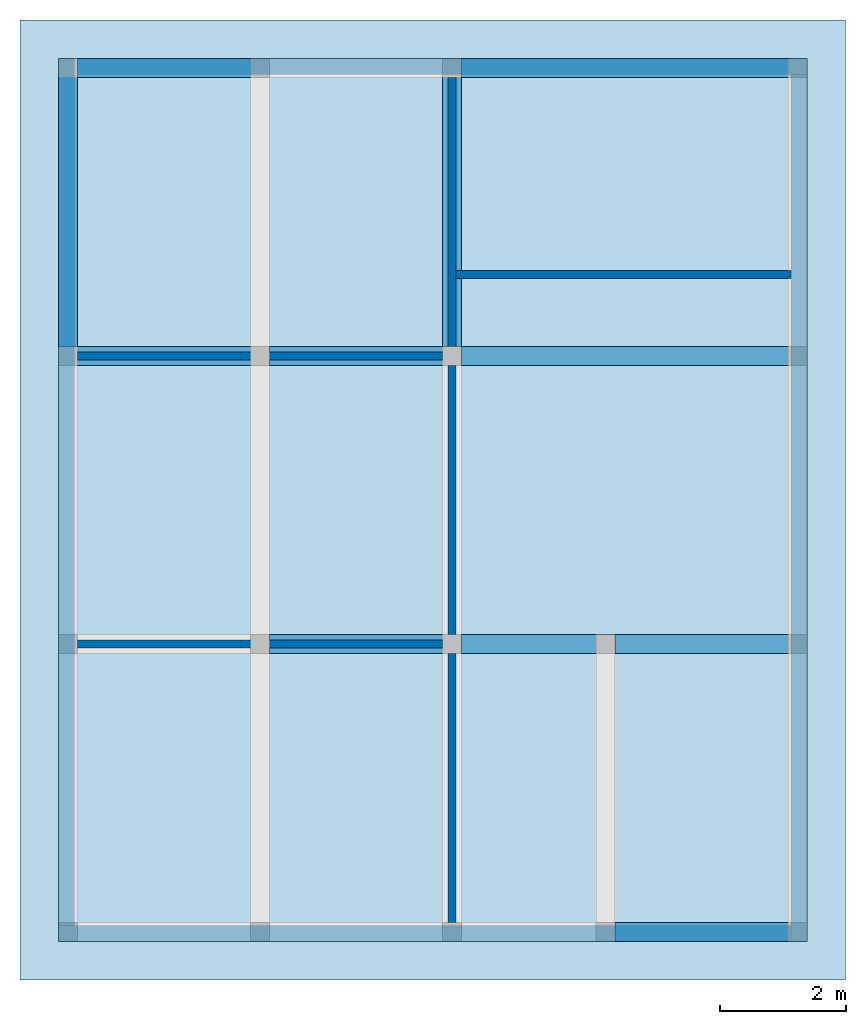
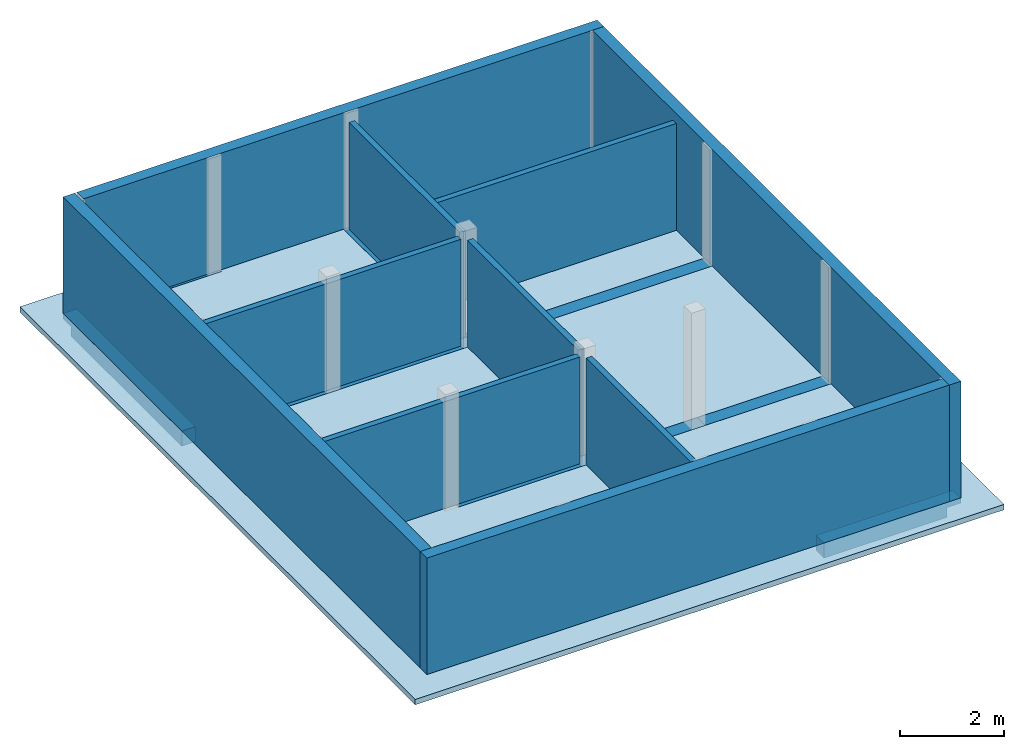
# One storey, part 2 of 2: 11 beams, 10 walls, 1 slab.
"""IFC2X3 building model written with IfcOpenShell, lengths in feet."""

import ifcopenshell
import ifcopenshell.guid

model = None  # the IFC model being written
_history = None  # IfcOwnerHistory: only IFC2X3 demands one
_inside = {}  # id of a spatial element -> (the spatial element, [elements in it])
_under = {}  # id of a project, library or spatial element -> (it, [spatial elements below it])
_declared = {}  # id of a project -> (the project, [libraries it declares])
_typed = {}  # id of a type object -> (the type object, [elements of that type])
_made_of = {}  # id of a material, layer set ... -> (it, [elements and type objects made of it])


def new_model(schema):
    """Start an empty IFC model of exactly this schema.

    Asked for "IFC4X3", IfcOpenShell would pick the latest addendum, in which some entities
    have other attributes; the version numbers below select the first issue.
    IFC2X3 requires an IfcOwnerHistory on every rooted entity: one is made here for all.
    """
    global model, _history
    if schema == "IFC4X3":
        model = ifcopenshell.file(schema_version=(4, 3, 0, 0))
    else:
        model = ifcopenshell.file(schema=schema)
    _inside.clear()
    _under.clear()
    _declared.clear()
    _typed.clear()
    _made_of.clear()
    _history = None
    if model.schema == "IFC2X3":
        org = make("IfcOrganization", Name="unknown")
        user = make(
            "IfcPersonAndOrganization",
            ThePerson=make("IfcPerson", FamilyName="unknown"),
            TheOrganization=org,
        )
        app = make(
            "IfcApplication",
            ApplicationDeveloper=org,
            Version="unknown",
            ApplicationFullName="unknown",
            ApplicationIdentifier="unknown",
        )
        _history = make(
            "IfcOwnerHistory",
            OwningUser=user,
            OwningApplication=app,
            ChangeAction="ADDED",
            CreationDate=0,
        )
    return model


def make(cls, **values):
    """One entity of the class cls with the attributes given. An attribute that is None is left unset."""
    return model.create_entity(
        cls, **{name: value for name, value in values.items() if value is not None}
    )


def entity(cls, *values):
    """Any entity or typed value of the class cls, its attributes in the order of the schema. None: left unset."""
    e = model.create_entity(cls)
    for i, value in enumerate(values):
        if value is not None:
            e[i] = value
    return e


def rooted(cls, **values):
    """An entity with a GlobalId (a new one), such as an element, a storey or a relation."""
    return make(cls, GlobalId=ifcopenshell.guid.new(), OwnerHistory=_history, **values)


def si_unit(unit_type, name, prefix=None):
    """IfcSIUnit, for example si_unit("LENGTHUNIT", "METRE", prefix="MILLI")."""
    return make("IfcSIUnit", UnitType=unit_type, Prefix=prefix, Name=name)


def converted_unit(unit_type, name, factor, base, dimensions=None, offset=None):
    """IfcConversionBasedUnit, such as the inch: factor (a typed value) times the base unit."""
    return make(
        "IfcConversionBasedUnit"
        if offset is None
        else "IfcConversionBasedUnitWithOffset",
        ConversionOffset=offset,
        Dimensions=None
        if dimensions is None
        else entity("IfcDimensionalExponents", *dimensions),
        UnitType=unit_type,
        Name=name,
        ConversionFactor=make(
            "IfcMeasureWithUnit", ValueComponent=factor, UnitComponent=base
        ),
    )


def derived_unit(unit_type, elements):
    """IfcDerivedUnit: a product of units, each with its exponent."""
    return make(
        "IfcDerivedUnit",
        Elements=[
            make("IfcDerivedUnitElement", Unit=unit, Exponent=power)
            for unit, power in elements
        ],
        UnitType=unit_type,
    )


def assignment(units):
    """IfcUnitAssignment: the units of a project."""
    return None if units is None else make("IfcUnitAssignment", Units=units)


def point(xyz):
    """IfcCartesianPoint."""
    return None if xyz is None else make("IfcCartesianPoint", Coordinates=xyz)


def direction(xyz):
    """IfcDirection."""
    return None if xyz is None else make("IfcDirection", DirectionRatios=xyz)


def frame(location, z_axis=None, x_axis=None):
    """IfcAxis2Placement3D, a coordinate frame: its origin and axes. An axis left out is left unset."""
    return make(
        "IfcAxis2Placement3D",
        Location=point(location),
        Axis=direction(z_axis),
        RefDirection=direction(x_axis),
    )


def frame_2d(location, x_axis=None):
    """IfcAxis2Placement2D, a coordinate frame in the plane: its origin and x axis."""
    return make(
        "IfcAxis2Placement2D", Location=point(location), RefDirection=direction(x_axis)
    )


def origin():
    """The frame at (0, 0, 0) with its axes left unset."""
    return frame((0.0, 0.0, 0.0))


def origin_2d_with_axis():
    """The frame at (0, 0) in the plane with the x axis (1, 0) written out."""
    return frame_2d((0.0, 0.0), x_axis=(1.0, 0.0))


def place(relative_to, where):
    """IfcLocalPlacement: puts the frame where relative to a parent placement (None: the world)."""
    return make(
        "IfcLocalPlacement", PlacementRelTo=relative_to, RelativePlacement=where
    )


def context(
    kind, dimensions, precision=None, world=None, true_north=None, identifier=None
):
    """IfcGeometricRepresentationContext, for example the 3D "Model" context."""
    return make(
        "IfcGeometricRepresentationContext",
        ContextIdentifier=identifier,
        ContextType=kind,
        CoordinateSpaceDimension=dimensions,
        Precision=precision,
        WorldCoordinateSystem=world,
        TrueNorth=true_north,
    )


def subcontext(parent, identifier, kind, view, scale=None):
    """IfcGeometricRepresentationSubContext, for example "Body" below "Model"."""
    return make(
        "IfcGeometricRepresentationSubContext",
        ContextIdentifier=identifier,
        ContextType=kind,
        ParentContext=parent,
        TargetScale=scale,
        TargetView=view,
    )


def project(units=None, contexts=None):
    """IfcProject with its units and contexts."""
    return rooted(
        "IfcProject",
        Name="project",
        RepresentationContexts=contexts,
        UnitsInContext=assignment(units),
    )


def spatial(cls, under=None, at=None, **own):
    """A site, building, storey or space (cls), placed at a placement, below another one or the project."""
    s = rooted(cls, ObjectPlacement=at, **own)
    if under is not None:
        _under.setdefault(under.id(), (under, []))[1].append(s)
    return s


def profile(cls, at=None, kind="AREA", **sizes):
    """A parametric profile (cls). Its sizes go by their IFC names, for example OverallWidth=200.0."""
    return make(cls, ProfileType=kind, Position=at, **sizes)


def rectangle(**sizes):
    """IfcRectangleProfileDef."""
    return profile("IfcRectangleProfileDef", **sizes)


def extrude(swept, where, along, depth):
    """IfcExtrudedAreaSolid: the profile swept, set in the frame where, extruded along a direction by depth."""
    return make(
        "IfcExtrudedAreaSolid",
        SweptArea=swept,
        Position=where,
        ExtrudedDirection=direction(along),
        Depth=depth,
    )


def faces_of(points, faces, orient=None, outer=None):
    """IfcFace entities. A face is a list of loops; a loop is a list of indices into points, from 0.

    orient and outer hold one flag for each loop. By default every Orientation is true, the
    first loop of a face is its IfcFaceOuterBound and the others are IfcFaceBound.
    """
    made = []
    for i, loops in enumerate(faces):
        bounds = []
        for j, loop in enumerate(loops):
            is_outer = j == 0 if outer is None else outer[i][j]
            bounds.append(
                make(
                    "IfcFaceOuterBound" if is_outer else "IfcFaceBound",
                    Bound=make("IfcPolyLoop", Polygon=[points[k] for k in loop]),
                    Orientation=True if orient is None else orient[i][j],
                )
            )
        made.append(make("IfcFace", Bounds=bounds))
    return made


def faceted_brep(points, faces, orient=None, outer=None, voids=None):
    """IfcFacetedBrep: a solid bounded by flat faces; with voids (closed shells), ...WithVoids."""
    shared = [point(p) for p in points]
    hull = make("IfcClosedShell", CfsFaces=faces_of(shared, faces, orient, outer))
    if voids is None:
        return make("IfcFacetedBrep", Outer=hull)
    return make(
        "IfcFacetedBrepWithVoids",
        Outer=hull,
        Voids=[
            make(cls, CfsFaces=faces_of(shared, fs, o, b)) for cls, fs, o, b in voids
        ],
    )


def shape(context_of_items, identifier, shape_type, items):
    """IfcShapeRepresentation: the items that make up one representation, for example the "Body"."""
    return make(
        "IfcShapeRepresentation",
        ContextOfItems=context_of_items,
        RepresentationIdentifier=identifier,
        RepresentationType=shape_type,
        Items=items,
    )


def material(Name=None, Category=None):
    """IfcMaterial."""
    return make("IfcMaterial", Name=Name, Category=Category)


def layer(
    of_material, thickness, ventilated=None, Name=None, Category=None, Priority=None
):
    """IfcMaterialLayer: one layer of a wall or slab, of a material (None: an air gap)."""
    return make(
        "IfcMaterialLayer",
        Material=of_material,
        LayerThickness=thickness,
        IsVentilated=ventilated,
        Name=Name,
        Category=Category,
        Priority=Priority,
    )


def layer_set(layers, Name=None):
    """IfcMaterialLayerSet."""
    return make("IfcMaterialLayerSet", MaterialLayers=layers, LayerSetName=Name)


def layer_usage(for_layer_set, set_direction, sense, offset, extent=None):
    """IfcMaterialLayerSetUsage: how a layer set lies in its element."""
    return make(
        "IfcMaterialLayerSetUsage",
        ForLayerSet=for_layer_set,
        LayerSetDirection=set_direction,
        DirectionSense=sense,
        OffsetFromReferenceLine=offset,
        ReferenceExtent=extent,
    )


def made_of(thing, what):
    """Note that an element or type object is made of a material, layer set ...; save() writes the relation."""
    if what is not None:
        _made_of.setdefault(what.id(), (what, []))[1].append(thing)
    return thing


def type_object(cls, material=None, **own):
    """A type object (cls), such as IfcWallType, which elements share."""
    return made_of(rooted(cls, **own), material)


def element(
    cls,
    number,
    at=None,
    inside=None,
    cuts=None,
    type_object=None,
    material=None,
    context=None,
    identifier="Body",
    shape_type=None,
    held_by="IfcProductDefinitionShape",
    body=None,
    shapes=None,
    **own,
):
    """One element of the class cls, such as IfcWall. Its Tag is "e" and its number.

    at: its placement. inside: the storey or other place that contains it. cuts: it is an
    opening in that element (IfcRelVoidsElement). A single representation is given by context,
    identifier, shape_type and body (its items); several are given by shapes. held_by: the class
    of the entity that holds the representations. save() writes the other relations.
    """
    e = rooted(cls, Tag="e%d" % number, ObjectPlacement=at, **own)
    if body is not None:
        shapes = [shape(context, identifier, shape_type, body)]
    if shapes is not None:
        e.Representation = make(held_by, Representations=shapes)
    if inside is not None:
        _inside.setdefault(inside.id(), (inside, []))[1].append(e)
    if cuts is not None:
        rooted(
            "IfcRelVoidsElement", RelatingBuildingElement=cuts, RelatedOpeningElement=e
        )
    if type_object is not None:
        _typed.setdefault(type_object.id(), (type_object, []))[1].append(e)
    return made_of(e, material)


def aggregate(whole, parts):
    """IfcRelAggregates: a whole, such as a stair, and the parts it consists of."""
    return rooted("IfcRelAggregates", RelatingObject=whole, RelatedObjects=parts)


def save(model, path):
    """Write the relations noted so far, then the file.

    IfcRelAggregates (storeys below a building ...), IfcRelContainedInSpatialStructure (elements
    in a storey), IfcRelDefinesByType, IfcRelAssociatesMaterial and IfcRelDeclares: one each for
    every whole, place, type object, material and project.
    """
    for whole, parts in _under.values():
        aggregate(whole, parts)
    for where, things in _inside.values():
        rooted(
            "IfcRelContainedInSpatialStructure",
            RelatedElements=things,
            RelatingStructure=where,
        )
    for kind, things in _typed.values():
        rooted("IfcRelDefinesByType", RelatedObjects=things, RelatingType=kind)
    for what, things in _made_of.values():
        rooted("IfcRelAssociatesMaterial", RelatedObjects=things, RelatingMaterial=what)
    for by, libraries in _declared.values():
        rooted("IfcRelDeclares", RelatingContext=by, RelatedDefinitions=libraries)
    model.write(path)


model = new_model("IFC2X3")

# Units and contexts
model_context = context("Model", 3, precision=0.0001, world=origin(), true_north=direction((6.123031769111886e-17, 1.0)))
body_context = subcontext(model_context, "Body", "Model", "MODEL_VIEW")
ifc_project = project(units=[converted_unit("LENGTHUNIT", "FOOT", entity("IfcLengthMeasure", 0.3048), si_unit("LENGTHUNIT", "METRE"), dimensions=[1, 0, 0, 0, 0, 0, 0]), converted_unit("AREAUNIT", "SQUARE FOOT", entity("IfcAreaMeasure", 0.09290304), si_unit("AREAUNIT", "SQUARE_METRE"), dimensions=[2, 0, 0, 0, 0, 0, 0]), converted_unit("VOLUMEUNIT", "CUBIC FOOT", entity("IfcVolumeMeasure", 0.028316846592000004), si_unit("VOLUMEUNIT", "CUBIC_METRE"), dimensions=[3, 0, 0, 0, 0, 0, 0]), converted_unit("PLANEANGLEUNIT", "DEGREE", entity("IfcPlaneAngleMeasure", 0.017453292519943278), si_unit("PLANEANGLEUNIT", "RADIAN"), dimensions=[0, 0, 0, 0, 0, 0, 0]), si_unit("MASSUNIT", "GRAM", prefix="KILO"), derived_unit("MASSDENSITYUNIT", [(si_unit("MASSUNIT", "GRAM", prefix="KILO"), 1), (si_unit("LENGTHUNIT", "METRE"), -3)]), derived_unit("IONCONCENTRATIONUNIT", [(si_unit("MASSUNIT", "GRAM", prefix="KILO"), 1), (si_unit("LENGTHUNIT", "METRE"), -3)]), derived_unit("MOMENTOFINERTIAUNIT", [(si_unit("LENGTHUNIT", "METRE"), 4)]), si_unit("TIMEUNIT", "SECOND"), si_unit("FREQUENCYUNIT", "HERTZ"), si_unit("THERMODYNAMICTEMPERATUREUNIT", "DEGREE_CELSIUS"), derived_unit("THERMALTRANSMITTANCEUNIT", [(si_unit("MASSUNIT", "GRAM", prefix="KILO"), 1), (si_unit("THERMODYNAMICTEMPERATUREUNIT", "KELVIN"), -1), (si_unit("TIMEUNIT", "SECOND"), -3)]), derived_unit("THERMALCONDUCTANCEUNIT", [(si_unit("MASSUNIT", "GRAM", prefix="KILO"), 1), (si_unit("THERMODYNAMICTEMPERATUREUNIT", "KELVIN"), -1), (si_unit("TIMEUNIT", "SECOND"), -3), (si_unit("LENGTHUNIT", "METRE"), 1)]), derived_unit("VOLUMETRICFLOWRATEUNIT", [(si_unit("LENGTHUNIT", "METRE"), 3), (si_unit("TIMEUNIT", "SECOND"), -1)]), derived_unit("MASSFLOWRATEUNIT", [(si_unit("MASSUNIT", "GRAM", prefix="KILO"), 1), (si_unit("TIMEUNIT", "SECOND"), -1)]), derived_unit("ROTATIONALFREQUENCYUNIT", [(si_unit("TIMEUNIT", "SECOND"), -1)]), si_unit("ELECTRICCURRENTUNIT", "AMPERE"), si_unit("ELECTRICVOLTAGEUNIT", "VOLT"), si_unit("POWERUNIT", "WATT"), converted_unit("FORCEUNIT", "KIP", entity("IfcForceMeasure", 2.088543423315013e-05), si_unit("FORCEUNIT", "NEWTON"), dimensions=[1, 1, -2, 0, 0, 0, 0]), si_unit("ILLUMINANCEUNIT", "LUX"), si_unit("LUMINOUSFLUXUNIT", "LUMEN"), si_unit("LUMINOUSINTENSITYUNIT", "CANDELA"), si_unit("ENERGYUNIT", "JOULE"), derived_unit("USERDEFINED", [(si_unit("MASSUNIT", "GRAM", prefix="KILO"), -1), (si_unit("LENGTHUNIT", "METRE"), -2), (si_unit("TIMEUNIT", "SECOND"), 3), (si_unit("LUMINOUSFLUXUNIT", "LUMEN"), 1)]), derived_unit("USERDEFINED", [(si_unit("MASSUNIT", "GRAM", prefix="KILO"), 1), (si_unit("TIMEUNIT", "SECOND"), -3), (si_unit("LENGTHUNIT", "METRE"), 3), (si_unit("ELECTRICCURRENTUNIT", "AMPERE"), -2)]), derived_unit("SOUNDPOWERUNIT", [(si_unit("MASSUNIT", "GRAM", prefix="KILO"), 1), (si_unit("TIMEUNIT", "SECOND"), -3), (si_unit("LENGTHUNIT", "METRE"), 2)]), derived_unit("SOUNDPRESSUREUNIT", [(si_unit("MASSUNIT", "GRAM", prefix="KILO"), 1), (si_unit("LENGTHUNIT", "METRE"), -1), (si_unit("TIMEUNIT", "SECOND"), -2)]), derived_unit("LINEARVELOCITYUNIT", [(si_unit("LENGTHUNIT", "METRE"), 1), (si_unit("TIMEUNIT", "SECOND"), -1)]), si_unit("PRESSUREUNIT", "PASCAL"), derived_unit("USERDEFINED", [(si_unit("MASSUNIT", "GRAM", prefix="KILO"), 1), (si_unit("LENGTHUNIT", "METRE"), -2), (si_unit("TIMEUNIT", "SECOND"), -2)]), derived_unit("LINEARFORCEUNIT", [(si_unit("MASSUNIT", "GRAM", prefix="KILO"), 1), (si_unit("TIMEUNIT", "SECOND"), -2)]), derived_unit("PLANARFORCEUNIT", [(si_unit("MASSUNIT", "GRAM", prefix="KILO"), 1), (si_unit("LENGTHUNIT", "METRE"), -1), (si_unit("TIMEUNIT", "SECOND"), -2)]), derived_unit("SPECIFICHEATCAPACITYUNIT", [(si_unit("THERMODYNAMICTEMPERATUREUNIT", "KELVIN"), -1), (si_unit("LENGTHUNIT", "METRE"), 2), (si_unit("TIMEUNIT", "SECOND"), -2)]), derived_unit("HEATFLUXDENSITYUNIT", [(si_unit("MASSUNIT", "GRAM", prefix="KILO"), 1), (si_unit("TIMEUNIT", "SECOND"), -3)]), derived_unit("HEATINGVALUEUNIT", [(si_unit("LENGTHUNIT", "METRE"), 2), (si_unit("TIMEUNIT", "SECOND"), -2)]), derived_unit("VAPORPERMEABILITYUNIT", [(si_unit("LENGTHUNIT", "METRE"), -1), (si_unit("TIMEUNIT", "SECOND"), 1)]), derived_unit("DYNAMICVISCOSITYUNIT", [(si_unit("MASSUNIT", "GRAM", prefix="KILO"), 1), (si_unit("TIMEUNIT", "SECOND"), -1), (si_unit("LENGTHUNIT", "METRE"), -1)]), derived_unit("THERMALEXPANSIONCOEFFICIENTUNIT", [(si_unit("THERMODYNAMICTEMPERATUREUNIT", "KELVIN"), -1)]), derived_unit("MODULUSOFELASTICITYUNIT", [(si_unit("MASSUNIT", "GRAM", prefix="KILO"), 1), (si_unit("LENGTHUNIT", "METRE"), -1), (si_unit("TIMEUNIT", "SECOND"), -2)]), derived_unit("ISOTHERMALMOISTURECAPACITYUNIT", [(si_unit("LENGTHUNIT", "METRE"), 3), (si_unit("MASSUNIT", "GRAM", prefix="KILO"), -1)]), derived_unit("MOISTUREDIFFUSIVITYUNIT", [(si_unit("TIMEUNIT", "SECOND"), -1), (si_unit("LENGTHUNIT", "METRE"), 2)]), derived_unit("MASSPERLENGTHUNIT", [(si_unit("MASSUNIT", "GRAM", prefix="KILO"), 1), (si_unit("LENGTHUNIT", "METRE"), -1)]), derived_unit("THERMALRESISTANCEUNIT", [(si_unit("MASSUNIT", "GRAM", prefix="KILO"), -1), (si_unit("TIMEUNIT", "SECOND"), 3), (si_unit("THERMODYNAMICTEMPERATUREUNIT", "KELVIN"), 1)]), derived_unit("ACCELERATIONUNIT", [(si_unit("LENGTHUNIT", "METRE"), 1), (si_unit("TIMEUNIT", "SECOND"), -2)]), derived_unit("ANGULARVELOCITYUNIT", [(si_unit("TIMEUNIT", "SECOND"), -1), (si_unit("PLANEANGLEUNIT", "RADIAN"), 1)]), derived_unit("LINEARSTIFFNESSUNIT", [(si_unit("MASSUNIT", "GRAM", prefix="KILO"), 1), (si_unit("TIMEUNIT", "SECOND"), -2)]), derived_unit("WARPINGCONSTANTUNIT", [(si_unit("LENGTHUNIT", "METRE"), 6)]), derived_unit("LINEARMOMENTUNIT", [(si_unit("MASSUNIT", "GRAM", prefix="KILO"), 1), (si_unit("LENGTHUNIT", "METRE"), 1), (si_unit("TIMEUNIT", "SECOND"), -2)]), derived_unit("TORQUEUNIT", [(si_unit("MASSUNIT", "GRAM", prefix="KILO"), 1), (si_unit("LENGTHUNIT", "METRE"), 2), (si_unit("TIMEUNIT", "SECOND"), -2)])], contexts=[model_context])

# Site, building, storey
site_placement = place(None, origin())
site = spatial("IfcSite", under=ifc_project, at=site_placement, CompositionType="ELEMENT")
building_placement = place(site_placement, origin())
building = spatial("IfcBuilding", under=site, at=building_placement, CompositionType="ELEMENT")
storey_placement = place(building_placement, frame((0.0, 0.0, 9.416666666668288)))
storey = spatial("IfcBuildingStorey", under=building, at=storey_placement, Name="First Floor", CompositionType="ELEMENT", Elevation=9.416666666668288)

# Beams
ifc_material_1 = material(Name="Concrete, Cast-in-Place gray")
beam_type = type_object("IfcBeamType", PredefinedType="NOTDEFINED")
for number, where in (
    (1, (38.37447801916311, -50.34124484724908, -1.1666666666666714)),
    (2, (20.374478019163327, -35.34124484724902, -1.1666666666666714)),
):
    element("IfcBeam", number, at=place(storey_placement, frame(where)), inside=storey, type_object=beam_type, material=ifc_material_1, context=body_context, shape_type="Brep", body=[
        faceted_brep([(10.0, 0.0, 1.1666666666666643), (10.0, 1.0, 1.1666666666666643), (9.0, 1.0, 1.1666666666666643), (0.0, 1.0, 1.1666666666666643), (0.0, 0.0, 1.1666666666666643), (9.0, 0.0, 1.1666666666666643), (0.0, 0.0, 0.7499999999983835), (0.0, 0.0, 0.0), (9.0, 0.0, 0.0), (9.0, 0.0, 0.7499999999983835), (10.0, 0.0, 0.7499999999983835), (0.0, 1.0, 0.0), (9.0, 1.0, 0.0), (10.0, 1.0, 0.7499999999983835), (9.0, 1.0, 0.7499999999983835), (0.0, 1.0, 0.7499999999983835)], [[[0, 1, 2, 3, 4, 5]], [[0, 5, 4, 6, 7, 8, 9, 10]], [[7, 11, 12, 8]], [[3, 2, 1, 13, 14, 12, 11, 15]], [[1, 0, 10, 13]], [[4, 3, 15, 11, 7, 6]], [[14, 9, 8, 12]], [[9, 14, 13, 10]]]),
    ])
beam_1_placement = place(storey_placement, frame((30.37447801916315, -35.34124484724903, -1.1666666666666732)))
element("IfcBeam", 3, at=beam_1_placement, inside=storey, type_object=beam_type, material=ifc_material_1, context=body_context, shape_type="Brep", body=[
    faceted_brep([(8.0, 0.0, 1.166666666666666), (8.0, 1.0, 1.166666666666666), (7.0, 1.0, 1.166666666666666), (0.0, 1.0, 1.166666666666666), (0.0, 0.0, 1.1666666666666679), (7.0, 0.0, 1.1666666666666679), (0.0, 0.0, 0.7499999999983853), (0.0, 0.0, 0.0), (7.0, 0.0, 0.0), (7.0, 0.0, 0.7499999999983853), (8.0, 0.0, 0.7499999999983853), (0.0, 1.0, 0.0), (7.0, 1.0, 0.0), (8.0, 1.0, 0.7499999999983853), (7.0, 1.0, 0.7499999999983853), (0.0, 1.0, 0.7499999999983853)], [[[0, 1, 2, 3, 4, 5]], [[0, 5, 4, 6, 7, 8, 9, 10]], [[7, 11, 12, 8]], [[3, 2, 1, 13, 14, 12, 11, 15]], [[1, 0, 10, 13]], [[4, 3, 15, 11, 7, 6]], [[14, 9, 8, 12]], [[9, 14, 13, 10]]]),
])
beam_2_placement = place(storey_placement, frame((38.37447801916313, -35.34124484724908, -1.1666666666666714)))
element("IfcBeam", 4, at=beam_2_placement, inside=storey, type_object=beam_type, material=ifc_material_1, context=body_context, shape_type="Brep", body=[
    faceted_brep([(10.0, 0.0, 1.1666666666666643), (10.0, 1.0, 1.1666666666666643), (9.0, 1.0, 1.1666666666666643), (0.0, 1.0, 1.1666666666666643), (0.0, 0.0, 1.1666666666666643), (9.0, 0.0, 1.1666666666666643), (0.0, 0.0, 0.7499999999983835), (0.0, 0.0, 0.0), (9.0, 0.0, 0.0), (9.0, 0.0, 0.7499999999983835), (10.0, 0.0, 0.7499999999983835), (0.0, 1.0, 0.0), (9.0, 1.0, 0.0), (10.0, 1.0, 0.7499999999983835), (9.0, 1.0, 0.7499999999983835), (0.0, 1.0, 0.7499999999983835)], [[[0, 1, 2, 3, 4, 5]], [[0, 5, 4, 6, 7, 8, 9, 10]], [[7, 11, 12, 8]], [[3, 2, 1, 13, 14, 12, 11, 15]], [[1, 0, 10, 13]], [[4, 3, 15, 11, 7, 6]], [[14, 9, 8, 12]], [[9, 14, 13, 10]]]),
])
beam_3_placement = place(storey_placement, frame((9.374478019163147, -20.341244847248984, -1.1666666666666714)))
element("IfcBeam", 5, at=beam_3_placement, inside=storey, type_object=beam_type, material=ifc_material_1, context=body_context, shape_type="Brep", body=[
    faceted_brep([(11.0, 0.0, 1.1666666666666643), (11.0, 1.0, 1.1666666666666643), (10.0, 1.0, 1.1666666666666643), (1.0, 1.0, 1.1666666666666643), (0.0, 1.0, 1.1666666666666643), (0.0, 0.0, 1.1666666666666643), (1.0, 0.0, 1.1666666666666643), (10.0, 0.0, 1.1666666666666643), (0.0, 0.0, 0.7499999999983835), (1.0, 0.0, 0.7499999999983835), (1.0, 0.0, 0.0), (10.0, 0.0, 0.0), (10.0, 0.0, 0.7499999999983835), (11.0, 0.0, 0.7499999999983835), (1.0, 1.0, 0.0), (10.0, 1.0, 0.0), (11.0, 1.0, 0.7499999999983835), (10.0, 1.0, 0.7499999999983835), (1.0, 1.0, 0.7499999999983835), (0.0, 1.0, 0.7499999999983835)], [[[0, 1, 2, 3, 4, 5, 6, 7]], [[0, 7, 6, 5, 8, 9, 10, 11, 12, 13]], [[10, 14, 15, 11]], [[4, 3, 2, 1, 16, 17, 15, 14, 18, 19]], [[1, 0, 13, 16]], [[5, 4, 19, 8]], [[9, 18, 14, 10]], [[18, 9, 8, 19]], [[17, 12, 11, 15]], [[12, 17, 16, 13]]]),
])
beam_4_placement = place(storey_placement, frame((20.374478019163355, -20.341244847249012, -1.1666666666666714)))
element("IfcBeam", 6, at=beam_4_placement, inside=storey, type_object=beam_type, material=ifc_material_1, context=body_context, shape_type="Brep", body=[
    faceted_brep([(10.0, 0.0, 1.1666666666666643), (10.0, 1.0, 1.1666666666666643), (9.0, 1.0, 1.1666666666666643), (0.0, 1.0, 1.1666666666666643), (0.0, 0.0, 1.1666666666666643), (9.0, 0.0, 1.1666666666666643), (0.0, 0.0, 0.7499999999983835), (0.0, 0.0, 0.0), (9.0, 0.0, 0.0), (9.0, 0.0, 0.7499999999983835), (10.0, 0.0, 0.7499999999983835), (0.0, 1.0, 0.0), (9.0, 1.0, 0.0), (10.0, 1.0, 0.7499999999983835), (9.0, 1.0, 0.7499999999983835), (0.0, 1.0, 0.7499999999983835)], [[[0, 1, 2, 3, 4, 5]], [[0, 5, 4, 6, 7, 8, 9, 10]], [[7, 11, 12, 8]], [[3, 2, 1, 13, 14, 12, 11, 15]], [[1, 0, 10, 13]], [[4, 3, 15, 11, 7, 6]], [[14, 9, 8, 12]], [[9, 14, 13, 10]]]),
])
beam_5_placement = place(storey_placement, frame((30.374478019163178, -20.341244847249072, -1.1666666666666732)))
element("IfcBeam", 7, at=beam_5_placement, inside=storey, type_object=beam_type, material=ifc_material_1, context=body_context, shape_type="Brep", body=[
    faceted_brep([(18.0, 0.0, 1.166666666666666), (18.0, 1.0, 1.166666666666666), (17.0, 1.0, 1.166666666666666), (0.0, 1.0, 1.166666666666666), (0.0, 0.0, 1.1666666666666679), (17.0, 0.0, 1.1666666666666679), (0.0, 0.0, 0.7499999999983853), (0.0, 0.0, 0.0), (17.0, 0.0, 0.0), (17.0, 0.0, 0.7499999999983853), (18.0, 0.0, 0.7499999999983853), (0.0, 1.0, 0.0), (17.0, 1.0, 0.0), (18.0, 1.0, 0.7499999999983853), (17.0, 1.0, 0.7499999999983853), (0.0, 1.0, 0.7499999999983853)], [[[0, 1, 2, 3, 4, 5]], [[0, 5, 4, 6, 7, 8, 9, 10]], [[7, 11, 12, 8]], [[3, 2, 1, 13, 14, 12, 11, 15]], [[1, 0, 10, 13]], [[4, 3, 15, 11, 7, 6]], [[14, 9, 8, 12]], [[9, 14, 13, 10]]]),
])
for number, where, z_axis, x_axis in (
    (8, (9.374478019162256, -19.34124484724894, -1.1666666666666732), (0.0, 0.0, 1.0), (0.0, -1.0, 0.0)),
    (9, (29.374478019162254, -19.341244847249, -1.1666666666666732), (0.0, 0.0, 1.0), (0.0, -1.0, 0.0)),
):
    element("IfcBeam", number, at=place(storey_placement, frame(where, z_axis=z_axis, x_axis=x_axis)), inside=storey, type_object=beam_type, material=ifc_material_1, context=body_context, shape_type="Brep", body=[
        faceted_brep([(-15.0, 1.0, 1.166666666666666), (-15.0, 0.0, 1.1666666666666679), (-14.0, 0.0, 1.1666666666666679), (0.0, 0.0, 1.166666666666666), (0.0, 1.0, 1.166666666666666), (-14.0, 1.0, 1.166666666666666), (-15.0, 0.0, 0.7499999999983853), (-14.0, 0.0, 0.7499999999983853), (-14.0, 0.0, 0.0), (0.0, 0.0, 0.0), (0.0, 0.0, 0.7499999999983853), (0.0, 1.0, 0.0), (-14.0, 1.0, 0.0), (0.0, 1.0, 0.7499999999983853), (-14.0, 1.0, 0.7499999999983853), (-15.0, 1.0, 0.7499999999983853)], [[[0, 1, 2, 3, 4, 5]], [[3, 2, 1, 6, 7, 8, 9, 10]], [[11, 9, 8, 12]], [[0, 5, 4, 13, 11, 12, 14, 15]], [[1, 0, 15, 6]], [[4, 3, 10, 9, 11, 13]], [[7, 14, 12, 8]], [[14, 7, 6, 15]]]),
    ])
beam_6_placement = place(storey_placement, frame((10.374478019163183, -5.341244847248929, -1.1666666666666714)))
element("IfcBeam", 10, at=beam_6_placement, inside=storey, type_object=beam_type, material=ifc_material_1, context=body_context, shape_type="Brep", body=[
    faceted_brep([(10.0, 0.0, 1.1666666666666643), (10.0, 1.0, 1.1666666666666643), (9.0, 1.0, 1.1666666666666643), (0.0, 1.0, 1.1666666666666643), (0.0, 0.0, 1.1666666666666643), (9.0, 0.0, 1.1666666666666643), (0.0, 0.0, 0.7499999999983835), (0.0, 0.0, 0.0), (9.0, 0.0, 0.0), (9.0, 0.0, 0.7499999999983835), (10.0, 0.0, 0.7499999999983835), (0.0, 1.0, 0.0), (9.0, 1.0, 0.0), (10.0, 1.0, 0.7499999999983835), (9.0, 1.0, 0.7499999999983835), (0.0, 1.0, 0.7499999999983835)], [[[0, 1, 2, 3, 4, 5]], [[0, 5, 4, 6, 7, 8, 9, 10]], [[7, 11, 12, 8]], [[3, 2, 1, 13, 14, 12, 11, 15]], [[1, 0, 10, 13]], [[4, 3, 15, 11, 7, 6]], [[14, 9, 8, 12]], [[9, 14, 13, 10]]]),
])
beam_7_placement = place(storey_placement, frame((30.374478019163202, -5.341244847249021, -1.1666666666666732)))
element("IfcBeam", 11, at=beam_7_placement, inside=storey, type_object=beam_type, material=ifc_material_1, context=body_context, shape_type="Brep", body=[
    faceted_brep([(18.0, 0.0, 1.166666666666666), (18.0, 1.0, 1.166666666666666), (17.0, 1.0, 1.166666666666666), (0.0, 1.0, 1.166666666666666), (0.0, 0.0, 1.1666666666666679), (17.0, 0.0, 1.1666666666666679), (0.0, 0.0, 0.7499999999983853), (0.0, 0.0, 0.0), (17.0, 0.0, 0.0), (17.0, 0.0, 0.7499999999983853), (18.0, 0.0, 0.7499999999983853), (0.0, 1.0, 0.0), (17.0, 1.0, 0.0), (18.0, 1.0, 0.7499999999983853), (17.0, 1.0, 0.7499999999983853), (0.0, 1.0, 0.7499999999983853)], [[[0, 1, 2, 3, 4, 5]], [[0, 5, 4, 6, 7, 8, 9, 10]], [[7, 11, 12, 8]], [[3, 2, 1, 13, 14, 12, 11, 15]], [[1, 0, 10, 13]], [[4, 3, 15, 11, 7, 6]], [[14, 9, 8, 12]], [[9, 14, 13, 10]]]),
])

# Slab
ifc_material_2 = material(Name="Default Floor")
ifc_layer_1 = layer(ifc_material_2, 0.4166666666666667)
ifc_layer_set_1 = layer_set([ifc_layer_1])
ifc_layer_usage_1 = layer_usage(ifc_layer_set_1, "AXIS3", "POSITIVE", 0.0)
slab_type = type_object("IfcSlabType", PredefinedType="FLOOR", material=ifc_layer_set_1)
slab_placement = place(storey_placement, origin())
element("IfcSlab", 12, at=slab_placement, inside=storey, type_object=slab_type, material=ifc_layer_usage_1, PredefinedType="FLOOR", context=body_context, shape_type="SweptSolid", body=[
    extrude(rectangle(XDim=50.00000000000018, YDim=42.99999999999993, at=origin_2d_with_axis()), frame((28.874478019162204, -27.34124484724897, 0.0), z_axis=(0.0, 0.0, -1.0), x_axis=(0.0, 1.0, 0.0)), (0.0, 0.0, 1.0), 0.4166666666666661),
])

# Walls
ifc_material_3 = material(Name="Default Wall")
ifc_layer_2 = layer(ifc_material_3, 0.041666666666666664)
ifc_layer_3 = layer(ifc_material_3, 0.75)
ifc_layer_4 = layer(ifc_material_3, 0.041666666666666664)
ifc_layer_set_2 = layer_set([ifc_layer_2, ifc_layer_3, ifc_layer_4])
ifc_layer_usage_2 = layer_usage(ifc_layer_set_2, "AXIS2", "NEGATIVE", 0.4166666666666667)
wall_type_1 = type_object("IfcWallType", PredefinedType="STANDARD", material=ifc_layer_set_2)
wall_1_placement = place(storey_placement, frame((10.37447801916223, -4.757911513915553, 0.0)))
element("IfcWallStandardCase", 13, at=wall_1_placement, inside=storey, type_object=wall_type_1, material=ifc_layer_usage_2, context=body_context, shape_type="SweptSolid", body=[
    extrude(rectangle(XDim=38.00000000000001, YDim=0.8333333333333339, at=frame_2d((19.000000000000004, 0.0), x_axis=(-1.0, 0.0))), origin(), (0.0, 0.0, 1.0), 8.999999999998618),
])
wall_2_placement = place(storey_placement, frame((47.957811352495575, -5.174578180582336, 0.0), z_axis=(0.0, 0.0, 1.0), x_axis=(0.0, -1.0, 0.0)))
element("IfcWallStandardCase", 14, at=wall_2_placement, inside=storey, type_object=wall_type_1, material=ifc_layer_usage_2, context=body_context, shape_type="SweptSolid", body=[
    extrude(rectangle(XDim=45.16666666666672, YDim=0.8333333333333286, at=frame_2d((22.58333333333336, -6.38378239159465e-16), x_axis=(-1.0, 0.0))), origin(), (0.0, 0.0, 1.0), 8.999999999998618),
])
wall_3_placement = place(storey_placement, frame((47.54114468582883, -49.924578180582394, 0.0), z_axis=(0.0, 0.0, 1.0), x_axis=(-1.0, 0.0, 0.0)))
element("IfcWallStandardCase", 15, at=wall_3_placement, inside=storey, type_object=wall_type_1, material=ifc_layer_usage_2, context=body_context, shape_type="SweptSolid", body=[
    extrude(rectangle(XDim=38.16666666666667, YDim=0.8333333333333286, at=frame_2d((19.083333333333336, -1.3600232051658168e-15), x_axis=(-1.0, 0.0))), origin(), (0.0, 0.0, 1.0), 8.999999999998618),
])
wall_4_placement = place(storey_placement, frame((9.79114468582883, -49.507911513915595, 0.0), z_axis=(0.0, 0.0, 1.0), x_axis=(0.0, 1.0, 0.0)))
element("IfcWallStandardCase", 16, at=wall_4_placement, inside=storey, type_object=wall_type_1, material=ifc_layer_usage_2, context=body_context, shape_type="SweptSolid", body=[
    extrude(rectangle(XDim=45.166666666666714, YDim=0.8333333333333321, at=frame_2d((22.583333333333357, 2.220446049250313e-16), x_axis=(-1.0, 0.0))), origin(), (0.0, 0.0, 1.0), 8.999999999998618),
])
ifc_layer_5 = layer(ifc_material_3, 0.4166666666666667)
ifc_layer_set_3 = layer_set([ifc_layer_5])
ifc_layer_usage_3 = layer_usage(ifc_layer_set_3, "AXIS2", "NEGATIVE", 0.20833333333333334)
wall_type_2 = type_object("IfcWallType", PredefinedType="STANDARD", material=ifc_layer_set_3)
wall_5_placement = place(storey_placement, frame((10.37447801916221, -19.841244847248937, 0.0)))
element("IfcWallStandardCase", 17, at=wall_5_placement, inside=storey, type_object=wall_type_2, material=ifc_layer_usage_3, context=body_context, shape_type="SweptSolid", body=[
    extrude(rectangle(XDim=19.0, YDim=0.4166666666666643, at=frame_2d((9.5, 0.0), x_axis=(-1.0, 0.0))), origin(), (0.0, 0.0, 1.0), 8.249999999998618),
])
wall_6_placement = place(storey_placement, frame((29.87447801916221, -19.341244847248994, 0.0), z_axis=(0.0, 0.0, 1.0), x_axis=(0.0, 1.0, 0.0)))
element("IfcWallStandardCase", 18, at=wall_6_placement, inside=storey, type_object=wall_type_2, material=ifc_layer_usage_3, context=body_context, shape_type="SweptSolid", body=[
    extrude(rectangle(XDim=14.000000000000046, YDim=0.4166666666666643, at=frame_2d((7.000000000000023, 0.0), x_axis=(-1.0, 0.0))), origin(), (0.0, 0.0, 1.0), 8.249999999998618),
])
wall_7_placement = place(storey_placement, frame((29.87447801916221, -20.341244847249, 0.0), z_axis=(0.0, 0.0, 1.0), x_axis=(0.0, -1.0, 0.0)))
element("IfcWallStandardCase", 19, at=wall_7_placement, inside=storey, type_object=wall_type_2, material=ifc_layer_usage_3, context=body_context, shape_type="SweptSolid", body=[
    extrude(rectangle(XDim=13.999999999999986, YDim=0.4166666666666643, at=frame_2d((6.999999999999993, 0.0), x_axis=(-1.0, 0.0))), origin(), (0.0, 0.0, 1.0), 8.249999999998618),
])
wall_8_placement = place(storey_placement, frame((29.37447801916219, -34.841244847248994, 0.0), z_axis=(0.0, 0.0, 1.0), x_axis=(-1.0, 0.0, 0.0)))
element("IfcWallStandardCase", 20, at=wall_8_placement, inside=storey, type_object=wall_type_2, material=ifc_layer_usage_3, context=body_context, shape_type="SweptSolid", body=[
    extrude(rectangle(XDim=19.000000000000007, YDim=0.4166666666666714, at=frame_2d((9.500000000000004, 0.0), x_axis=(-1.0, 0.0))), origin(), (0.0, 0.0, 1.0), 8.249999999998618),
])
wall_9_placement = place(storey_placement, frame((29.87447801916219, -35.341244847249, 0.0), z_axis=(0.0, 0.0, 1.0), x_axis=(0.0, -1.0, 0.0)))
element("IfcWallStandardCase", 21, at=wall_9_placement, inside=storey, type_object=wall_type_2, material=ifc_layer_usage_3, context=body_context, shape_type="SweptSolid", body=[
    extrude(rectangle(XDim=13.999999999999986, YDim=0.4166666666666643, at=frame_2d((6.999999999999993, 0.0), x_axis=(-1.0, 0.0))), origin(), (0.0, 0.0, 1.0), 8.249999999998618),
])
wall_10_placement = place(storey_placement, frame((30.082811352495554, -15.591244847248992, 0.0)))
element("IfcWallStandardCase", 22, at=wall_10_placement, inside=storey, type_object=wall_type_2, material=ifc_layer_usage_3, context=body_context, shape_type="SweptSolid", body=[
    extrude(rectangle(XDim=17.458333333333336, YDim=0.41666666666666785, at=frame_2d((8.729166666666668, -1.3877787807814457e-16), x_axis=(-1.0, 0.0))), origin(), (0.0, 0.0, 1.0), 8.249999999998618),
])

save(model, "model.ifc")
